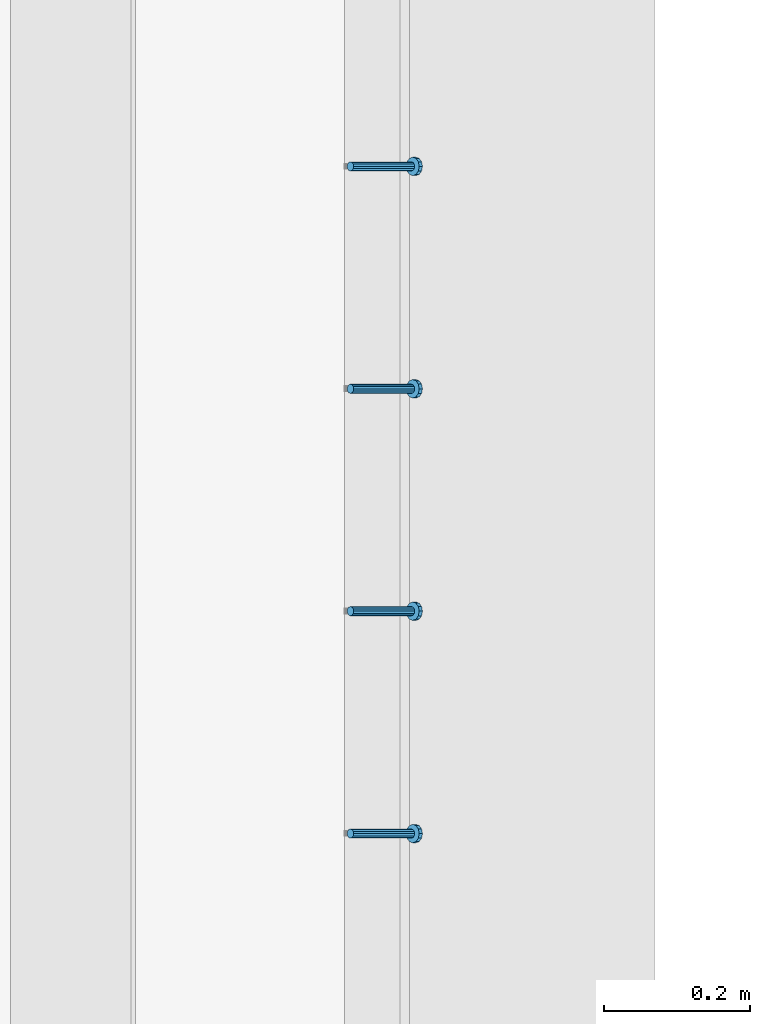
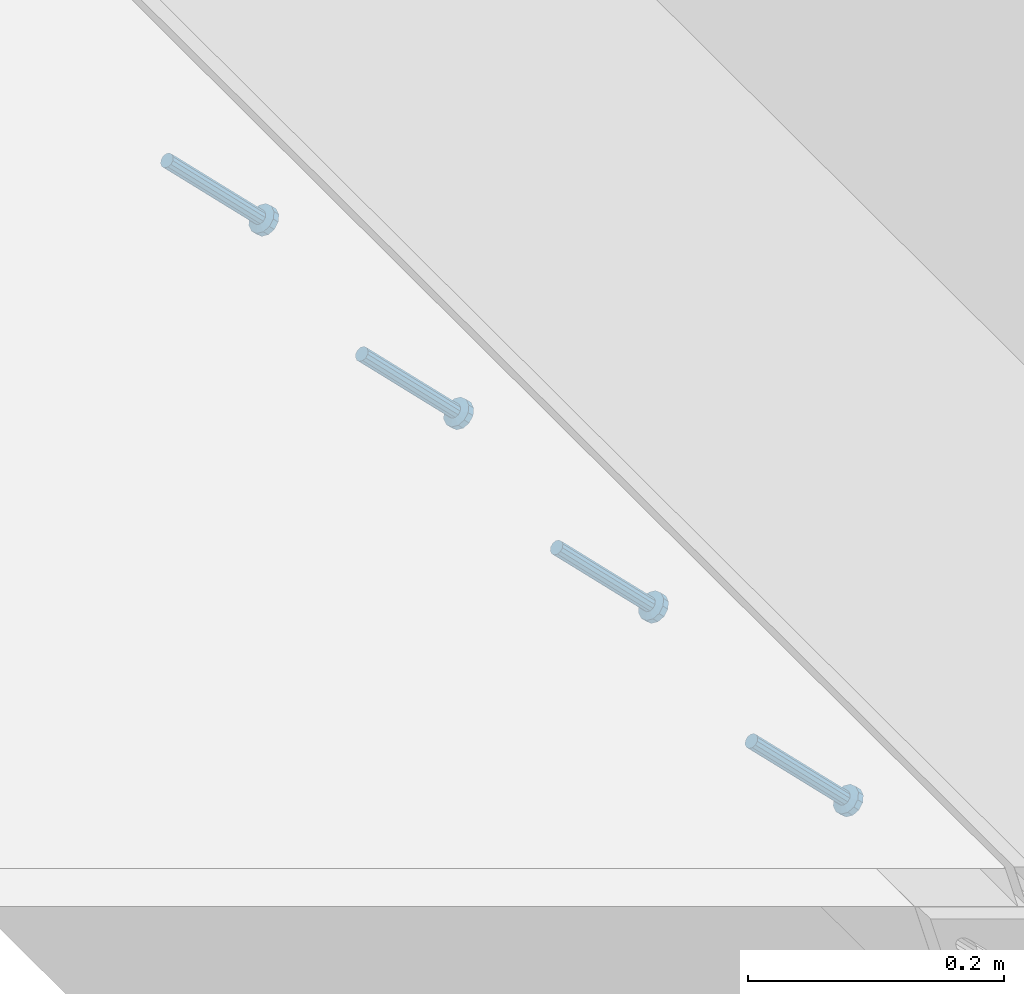
# One storey, part 2268 of 3843: 4 members, 1 element without a shape of its own.
"""IFC2X3 building model written with IfcOpenShell, lengths in millimetres."""

from ifc_helpers import new_model, si_unit, frame, origin_with_axes, place, context, subcontext, project, spatial, faceted_brep, material, type_object, element, aggregate, save


model = new_model("IFC2X3")

# Units and contexts
model_context = context("Model", 3, precision=1e-05, world=origin_with_axes())
body_context = subcontext(model_context, "Body", "Model", "MODEL_VIEW")
ifc_project = project(units=[si_unit("LENGTHUNIT", "METRE", prefix="MILLI"), si_unit("AREAUNIT", "SQUARE_METRE"), si_unit("VOLUMEUNIT", "CUBIC_METRE"), si_unit("MASSUNIT", "GRAM", prefix="KILO"), si_unit("TIMEUNIT", "SECOND"), si_unit("PLANEANGLEUNIT", "RADIAN"), si_unit("SOLIDANGLEUNIT", "STERADIAN"), si_unit("THERMODYNAMICTEMPERATUREUNIT", "DEGREE_CELSIUS"), si_unit("LUMINOUSINTENSITYUNIT", "LUMEN")], contexts=[model_context])

# Site, building, storey
site_placement = place(None, origin_with_axes())
site = spatial("IfcSite", under=ifc_project, at=site_placement, CompositionType="ELEMENT")
building_placement = place(site_placement, origin_with_axes())
building = spatial("IfcBuilding", under=site, at=building_placement, Name="Undefined", CompositionType="ELEMENT")
storey_placement = place(building_placement, origin_with_axes())
storey = spatial("IfcBuildingStorey", under=building, at=storey_placement, Name="Undefined", CompositionType="ELEMENT", Elevation=0.0)

# Assembly, members
assembly_placement = place(storey_placement, origin_with_axes())
assembly = element("IfcElementAssembly", 1, at=assembly_placement, inside=storey, Name="EMBED_ANGLE", AssemblyPlace="NOTDEFINED", PredefinedType="RIGID_FRAME")
ifc_material = material(Name="STEEL/A108")
member_type = type_object("IfcMemberType", PredefinedType="NOTDEFINED")
member_1_placement = place(assembly_placement, frame((59660.5996396484, 46761.2722717285, 30446.6625), z_axis=(0.0, 1.0, 0.0), x_axis=(0.707106781186548, 0.0, -0.707106781186548)))
member_1 = element("IfcMember", 2, at=member_1_placement, type_object=member_type, material=ifc_material, Name="HEADED STUD ANCHOR", context=body_context, shape_type="Brep", body=[
    faceted_brep([(7.27595761418343e-12, -3.18000006675175, 5.5), (0.0, -5.49999999998363, 3.1800000667572), (118.110000000976, -5.49999999999091, 3.1800000667572), (118.110000000983, -3.18000006675175, 5.5), (0.0, -6.3499999046162, 0.0), (118.110000000968, -6.34999990461256, 0.0), (0.0, -5.49999999998363, -3.1800000667572), (118.110000000976, -5.49999999999091, -3.1800000667572), (7.27595761418343e-12, -3.18000006675175, -5.5), (118.110000000983, -3.18000006675175, -5.5), (7.27595761418343e-12, -1.81898940354586e-12, -6.34999990463257), (118.110000000968, -1.81898940354586e-12, -6.34999990463257), (0.0, 3.18000006675175, -5.5), (118.110000000968, 3.18000006674811, -5.5), (7.27595761418343e-12, 5.49999999998363, -3.1800000667572), (118.110000000983, 5.49999999998363, -3.1800000667572), (7.27595761418343e-12, 6.3499999046162, 0.0), (118.110000000976, 6.34999990461256, 0.0), (7.27595761418343e-12, 5.49999999998363, 3.1800000667572), (118.110000000983, 5.49999999998363, 3.1800000667572), (0.0, 3.18000006675175, 5.5), (118.110000000968, 3.18000006674811, 5.5), (7.27595761418343e-12, -1.81898940354586e-12, 6.34999990463257), (118.110000000968, -1.81898940354586e-12, 6.34999990463257), (120.650000000991, -10.9899997710909, 6.34999990463257), (120.650000000998, -6.34000015257152, 10.9899997711182), (120.650000000991, -12.6999998092379, 0.0), (120.650000000991, -10.9899997710909, -6.34999990463257), (120.650000000998, -6.34000015257152, -10.9899997711182), (120.650000000991, -1.81898940354586e-12, -12.6899995803833), (120.650000000991, 6.34000015257152, -10.9899997711182), (120.650000000998, 10.9899997710909, -6.34999990463257), (120.650000000991, 12.6999998092342, 0.0), (120.650000000998, 10.9899997710909, 6.34999990463257), (120.650000000991, 6.34000015257152, 10.9899997711182), (120.650000000991, -1.81898940354586e-12, 12.6899995803833), (127.000000001048, -10.9899997710945, 6.34999990463257), (127.000000001048, -6.34000015257152, 10.9899997711182), (127.000000001048, -12.6999998092342, 0.0), (127.000000001048, -10.9899997710945, -6.34999990463257), (127.000000001048, -6.34000015257152, -10.9899997711182), (127.000000001048, 1.81898940354586e-12, -12.6899995803833), (127.000000001048, 6.34000015256788, -10.9899997711182), (127.000000001048, 10.9899997710909, -6.34999990463257), (127.000000001048, 12.6999998092379, 0.0), (127.000000001048, 10.9899997710909, 6.34999990463257), (127.000000001048, 6.34000015256788, 10.9899997711182), (127.000000001048, 1.81898940354586e-12, 12.6899995803833)], [[[0, 1, 2, 3]], [[1, 4, 5, 2]], [[4, 6, 7, 5]], [[6, 8, 9, 7]], [[8, 10, 11, 9]], [[10, 12, 13, 11]], [[12, 14, 15, 13]], [[14, 16, 17, 15]], [[16, 18, 19, 17]], [[18, 20, 21, 19]], [[20, 22, 23, 21]], [[22, 0, 3, 23]], [[22, 20, 18, 16, 14, 12, 10, 8, 6, 4, 1, 0]], [[3, 2, 24, 25]], [[2, 5, 26, 24]], [[5, 7, 27, 26]], [[7, 9, 28, 27]], [[9, 11, 29, 28]], [[11, 13, 30, 29]], [[13, 15, 31, 30]], [[15, 17, 32, 31]], [[17, 19, 33, 32]], [[19, 21, 34, 33]], [[21, 23, 35, 34]], [[23, 3, 25, 35]], [[25, 24, 36, 37]], [[24, 26, 38, 36]], [[26, 27, 39, 38]], [[27, 28, 40, 39]], [[28, 29, 41, 40]], [[29, 30, 42, 41]], [[30, 31, 43, 42]], [[31, 32, 44, 43]], [[32, 33, 45, 44]], [[33, 34, 46, 45]], [[34, 35, 47, 46]], [[35, 25, 37, 47]], [[38, 39, 40, 41, 42, 43, 44, 45, 46, 47, 37, 36]]]),
])
member_2_placement = place(assembly_placement, frame((59660.5996396484, 47066.0722717285, 30446.6625), z_axis=(0.0, 1.0, 0.0), x_axis=(0.707106781186548, 0.0, -0.707106781186548)))
member_2 = element("IfcMember", 3, at=member_2_placement, type_object=member_type, material=ifc_material, Name="HEADED STUD ANCHOR", context=body_context, shape_type="Brep", body=[
    faceted_brep([(7.27595761418343e-12, -3.18000006675175, 5.5), (0.0, -5.49999999998363, 3.1800000667572), (118.110000000976, -5.49999999999091, 3.1800000667572), (118.110000000983, -3.18000006675175, 5.5), (0.0, -6.3499999046162, 0.0), (118.110000000968, -6.34999990461256, 0.0), (0.0, -5.49999999998363, -3.1800000667572), (118.110000000976, -5.49999999999091, -3.1800000667572), (7.27595761418343e-12, -3.18000006675175, -5.5), (118.110000000983, -3.18000006675175, -5.5), (7.27595761418343e-12, -1.81898940354586e-12, -6.34999990463257), (118.110000000968, -1.81898940354586e-12, -6.34999990463257), (0.0, 3.18000006675175, -5.5), (118.110000000968, 3.18000006674811, -5.5), (7.27595761418343e-12, 5.49999999998363, -3.1800000667572), (118.110000000983, 5.49999999998363, -3.1800000667572), (7.27595761418343e-12, 6.3499999046162, 0.0), (118.110000000976, 6.34999990461256, 0.0), (7.27595761418343e-12, 5.49999999998363, 3.1800000667572), (118.110000000983, 5.49999999998363, 3.1800000667572), (0.0, 3.18000006675175, 5.5), (118.110000000968, 3.18000006674811, 5.5), (7.27595761418343e-12, -1.81898940354586e-12, 6.34999990463257), (118.110000000968, -1.81898940354586e-12, 6.34999990463257), (120.650000000991, -10.9899997710909, 6.34999990463257), (120.650000000998, -6.34000015257152, 10.9899997711182), (120.650000000991, -12.6999998092379, 0.0), (120.650000000991, -10.9899997710909, -6.34999990463257), (120.650000000998, -6.34000015257152, -10.9899997711182), (120.650000000991, -1.81898940354586e-12, -12.6899995803833), (120.650000000991, 6.34000015257152, -10.9899997711182), (120.650000000998, 10.9899997710909, -6.34999990463257), (120.650000000991, 12.6999998092342, 0.0), (120.650000000998, 10.9899997710909, 6.34999990463257), (120.650000000991, 6.34000015257152, 10.9899997711182), (120.650000000991, -1.81898940354586e-12, 12.6899995803833), (127.000000001048, -10.9899997710945, 6.34999990463257), (127.000000001048, -6.34000015257152, 10.9899997711182), (127.000000001048, -12.6999998092342, 0.0), (127.000000001048, -10.9899997710945, -6.34999990463257), (127.000000001048, -6.34000015257152, -10.9899997711182), (127.000000001048, 1.81898940354586e-12, -12.6899995803833), (127.000000001048, 6.34000015256788, -10.9899997711182), (127.000000001048, 10.9899997710909, -6.34999990463257), (127.000000001048, 12.6999998092379, 0.0), (127.000000001048, 10.9899997710909, 6.34999990463257), (127.000000001048, 6.34000015256788, 10.9899997711182), (127.000000001048, 1.81898940354586e-12, 12.6899995803833)], [[[0, 1, 2, 3]], [[1, 4, 5, 2]], [[4, 6, 7, 5]], [[6, 8, 9, 7]], [[8, 10, 11, 9]], [[10, 12, 13, 11]], [[12, 14, 15, 13]], [[14, 16, 17, 15]], [[16, 18, 19, 17]], [[18, 20, 21, 19]], [[20, 22, 23, 21]], [[22, 0, 3, 23]], [[22, 20, 18, 16, 14, 12, 10, 8, 6, 4, 1, 0]], [[3, 2, 24, 25]], [[2, 5, 26, 24]], [[5, 7, 27, 26]], [[7, 9, 28, 27]], [[9, 11, 29, 28]], [[11, 13, 30, 29]], [[13, 15, 31, 30]], [[15, 17, 32, 31]], [[17, 19, 33, 32]], [[19, 21, 34, 33]], [[21, 23, 35, 34]], [[23, 3, 25, 35]], [[25, 24, 36, 37]], [[24, 26, 38, 36]], [[26, 27, 39, 38]], [[27, 28, 40, 39]], [[28, 29, 41, 40]], [[29, 30, 42, 41]], [[30, 31, 43, 42]], [[31, 32, 44, 43]], [[32, 33, 45, 44]], [[33, 34, 46, 45]], [[34, 35, 47, 46]], [[35, 25, 37, 47]], [[38, 39, 40, 41, 42, 43, 44, 45, 46, 47, 37, 36]]]),
])
member_3_placement = place(assembly_placement, frame((59660.5996396484, 47370.8722717285, 30446.6625), z_axis=(0.0, 1.0, 0.0), x_axis=(0.707106781186548, 0.0, -0.707106781186548)))
member_3 = element("IfcMember", 4, at=member_3_placement, type_object=member_type, material=ifc_material, Name="HEADED STUD ANCHOR", context=body_context, shape_type="Brep", body=[
    faceted_brep([(7.27595761418343e-12, -3.18000006675175, 5.5), (0.0, -5.49999999998363, 3.1800000667572), (118.110000000976, -5.49999999999091, 3.1800000667572), (118.110000000983, -3.18000006675175, 5.5), (0.0, -6.3499999046162, 0.0), (118.110000000968, -6.34999990461256, 0.0), (0.0, -5.49999999998363, -3.1800000667572), (118.110000000976, -5.49999999999091, -3.1800000667572), (7.27595761418343e-12, -3.18000006675175, -5.5), (118.110000000983, -3.18000006675175, -5.5), (7.27595761418343e-12, -1.81898940354586e-12, -6.34999990463257), (118.110000000968, -1.81898940354586e-12, -6.34999990463257), (0.0, 3.18000006675175, -5.5), (118.110000000968, 3.18000006674811, -5.5), (7.27595761418343e-12, 5.49999999998363, -3.1800000667572), (118.110000000983, 5.49999999998363, -3.1800000667572), (7.27595761418343e-12, 6.3499999046162, 0.0), (118.110000000976, 6.34999990461256, 0.0), (7.27595761418343e-12, 5.49999999998363, 3.1800000667572), (118.110000000983, 5.49999999998363, 3.1800000667572), (0.0, 3.18000006675175, 5.5), (118.110000000968, 3.18000006674811, 5.5), (7.27595761418343e-12, -1.81898940354586e-12, 6.34999990463257), (118.110000000968, -1.81898940354586e-12, 6.34999990463257), (120.650000000991, -10.9899997710909, 6.34999990463257), (120.650000000998, -6.34000015257152, 10.9899997711182), (120.650000000991, -12.6999998092379, 0.0), (120.650000000991, -10.9899997710909, -6.34999990463257), (120.650000000998, -6.34000015257152, -10.9899997711182), (120.650000000991, -1.81898940354586e-12, -12.6899995803833), (120.650000000991, 6.34000015257152, -10.9899997711182), (120.650000000998, 10.9899997710909, -6.34999990463257), (120.650000000991, 12.6999998092342, 0.0), (120.650000000998, 10.9899997710909, 6.34999990463257), (120.650000000991, 6.34000015257152, 10.9899997711182), (120.650000000991, -1.81898940354586e-12, 12.6899995803833), (127.000000001048, -10.9899997710945, 6.34999990463257), (127.000000001048, -6.34000015257152, 10.9899997711182), (127.000000001048, -12.6999998092342, 0.0), (127.000000001048, -10.9899997710945, -6.34999990463257), (127.000000001048, -6.34000015257152, -10.9899997711182), (127.000000001048, 1.81898940354586e-12, -12.6899995803833), (127.000000001048, 6.34000015256788, -10.9899997711182), (127.000000001048, 10.9899997710909, -6.34999990463257), (127.000000001048, 12.6999998092379, 0.0), (127.000000001048, 10.9899997710909, 6.34999990463257), (127.000000001048, 6.34000015256788, 10.9899997711182), (127.000000001048, 1.81898940354586e-12, 12.6899995803833)], [[[0, 1, 2, 3]], [[1, 4, 5, 2]], [[4, 6, 7, 5]], [[6, 8, 9, 7]], [[8, 10, 11, 9]], [[10, 12, 13, 11]], [[12, 14, 15, 13]], [[14, 16, 17, 15]], [[16, 18, 19, 17]], [[18, 20, 21, 19]], [[20, 22, 23, 21]], [[22, 0, 3, 23]], [[22, 20, 18, 16, 14, 12, 10, 8, 6, 4, 1, 0]], [[3, 2, 24, 25]], [[2, 5, 26, 24]], [[5, 7, 27, 26]], [[7, 9, 28, 27]], [[9, 11, 29, 28]], [[11, 13, 30, 29]], [[13, 15, 31, 30]], [[15, 17, 32, 31]], [[17, 19, 33, 32]], [[19, 21, 34, 33]], [[21, 23, 35, 34]], [[23, 3, 25, 35]], [[25, 24, 36, 37]], [[24, 26, 38, 36]], [[26, 27, 39, 38]], [[27, 28, 40, 39]], [[28, 29, 41, 40]], [[29, 30, 42, 41]], [[30, 31, 43, 42]], [[31, 32, 44, 43]], [[32, 33, 45, 44]], [[33, 34, 46, 45]], [[34, 35, 47, 46]], [[35, 25, 37, 47]], [[38, 39, 40, 41, 42, 43, 44, 45, 46, 47, 37, 36]]]),
])
member_4_placement = place(assembly_placement, frame((59660.5996396484, 47675.6722717285, 30446.6625), z_axis=(0.0, 1.0, 0.0), x_axis=(0.707106781186548, 0.0, -0.707106781186548)))
member_4 = element("IfcMember", 5, at=member_4_placement, type_object=member_type, material=ifc_material, Name="HEADED STUD ANCHOR", context=body_context, shape_type="Brep", body=[
    faceted_brep([(7.27595761418343e-12, -3.18000006675175, 5.5), (0.0, -5.49999999998363, 3.1800000667572), (118.110000000976, -5.49999999999091, 3.1800000667572), (118.110000000983, -3.18000006675175, 5.5), (0.0, -6.3499999046162, 0.0), (118.110000000968, -6.34999990461256, 0.0), (0.0, -5.49999999998363, -3.1800000667572), (118.110000000976, -5.49999999999091, -3.1800000667572), (7.27595761418343e-12, -3.18000006675175, -5.5), (118.110000000983, -3.18000006675175, -5.5), (7.27595761418343e-12, -1.81898940354586e-12, -6.34999990463257), (118.110000000968, -1.81898940354586e-12, -6.34999990463257), (0.0, 3.18000006675175, -5.5), (118.110000000968, 3.18000006674811, -5.5), (7.27595761418343e-12, 5.49999999998363, -3.1800000667572), (118.110000000983, 5.49999999998363, -3.1800000667572), (7.27595761418343e-12, 6.3499999046162, 0.0), (118.110000000976, 6.34999990461256, 0.0), (7.27595761418343e-12, 5.49999999998363, 3.1800000667572), (118.110000000983, 5.49999999998363, 3.1800000667572), (0.0, 3.18000006675175, 5.5), (118.110000000968, 3.18000006674811, 5.5), (7.27595761418343e-12, -1.81898940354586e-12, 6.34999990463257), (118.110000000968, -1.81898940354586e-12, 6.34999990463257), (120.650000000991, -10.9899997710909, 6.34999990463257), (120.650000000998, -6.34000015257152, 10.9899997711182), (120.650000000991, -12.6999998092379, 0.0), (120.650000000991, -10.9899997710909, -6.34999990463257), (120.650000000998, -6.34000015257152, -10.9899997711182), (120.650000000991, -1.81898940354586e-12, -12.6899995803833), (120.650000000991, 6.34000015257152, -10.9899997711182), (120.650000000998, 10.9899997710909, -6.34999990463257), (120.650000000991, 12.6999998092342, 0.0), (120.650000000998, 10.9899997710909, 6.34999990463257), (120.650000000991, 6.34000015257152, 10.9899997711182), (120.650000000991, -1.81898940354586e-12, 12.6899995803833), (127.000000001048, -10.9899997710945, 6.34999990463257), (127.000000001048, -6.34000015257152, 10.9899997711182), (127.000000001048, -12.6999998092342, 0.0), (127.000000001048, -10.9899997710945, -6.34999990463257), (127.000000001048, -6.34000015257152, -10.9899997711182), (127.000000001048, 1.81898940354586e-12, -12.6899995803833), (127.000000001048, 6.34000015256788, -10.9899997711182), (127.000000001048, 10.9899997710909, -6.34999990463257), (127.000000001048, 12.6999998092379, 0.0), (127.000000001048, 10.9899997710909, 6.34999990463257), (127.000000001048, 6.34000015256788, 10.9899997711182), (127.000000001048, 1.81898940354586e-12, 12.6899995803833)], [[[0, 1, 2, 3]], [[1, 4, 5, 2]], [[4, 6, 7, 5]], [[6, 8, 9, 7]], [[8, 10, 11, 9]], [[10, 12, 13, 11]], [[12, 14, 15, 13]], [[14, 16, 17, 15]], [[16, 18, 19, 17]], [[18, 20, 21, 19]], [[20, 22, 23, 21]], [[22, 0, 3, 23]], [[22, 20, 18, 16, 14, 12, 10, 8, 6, 4, 1, 0]], [[3, 2, 24, 25]], [[2, 5, 26, 24]], [[5, 7, 27, 26]], [[7, 9, 28, 27]], [[9, 11, 29, 28]], [[11, 13, 30, 29]], [[13, 15, 31, 30]], [[15, 17, 32, 31]], [[17, 19, 33, 32]], [[19, 21, 34, 33]], [[21, 23, 35, 34]], [[23, 3, 25, 35]], [[25, 24, 36, 37]], [[24, 26, 38, 36]], [[26, 27, 39, 38]], [[27, 28, 40, 39]], [[28, 29, 41, 40]], [[29, 30, 42, 41]], [[30, 31, 43, 42]], [[31, 32, 44, 43]], [[32, 33, 45, 44]], [[33, 34, 46, 45]], [[34, 35, 47, 46]], [[35, 25, 37, 47]], [[38, 39, 40, 41, 42, 43, 44, 45, 46, 47, 37, 36]]]),
])
aggregate(assembly, [member_1, member_2, member_3, member_4])

save(model, "model.ifc")
